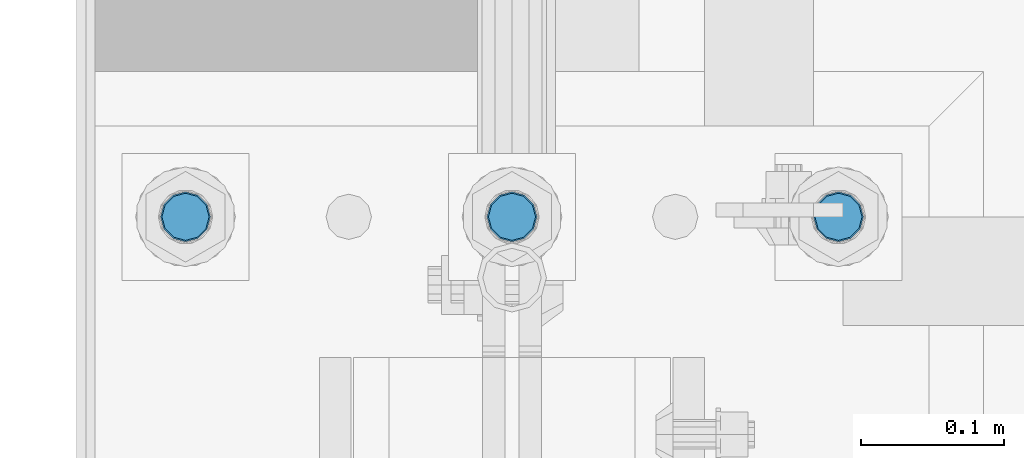
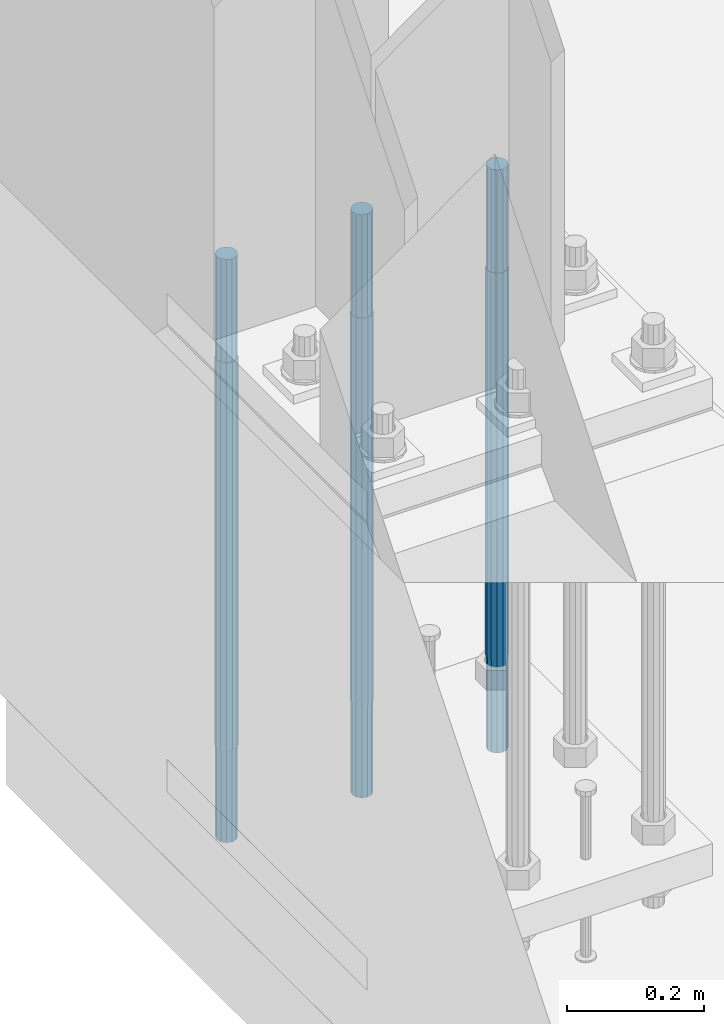
# One storey, part 565 of 1876: 3 columns, 1 element without a shape of its own.
"""IFC2X3 building model written with IfcOpenShell, lengths in millimetres."""

import ifcopenshell
import ifcopenshell.guid

model = None  # the IFC model being written
_history = None  # IfcOwnerHistory: only IFC2X3 demands one
_inside = {}  # id of a spatial element -> (the spatial element, [elements in it])
_under = {}  # id of a project, library or spatial element -> (it, [spatial elements below it])
_declared = {}  # id of a project -> (the project, [libraries it declares])
_typed = {}  # id of a type object -> (the type object, [elements of that type])
_made_of = {}  # id of a material, layer set ... -> (it, [elements and type objects made of it])


def new_model(schema):
    """Start an empty IFC model of exactly this schema.

    Asked for "IFC4X3", IfcOpenShell would pick the latest addendum, in which some entities
    have other attributes; the version numbers below select the first issue.
    IFC2X3 requires an IfcOwnerHistory on every rooted entity: one is made here for all.
    """
    global model, _history
    if schema == "IFC4X3":
        model = ifcopenshell.file(schema_version=(4, 3, 0, 0))
    else:
        model = ifcopenshell.file(schema=schema)
    _inside.clear()
    _under.clear()
    _declared.clear()
    _typed.clear()
    _made_of.clear()
    _history = None
    if model.schema == "IFC2X3":
        org = make("IfcOrganization", Name="unknown")
        user = make(
            "IfcPersonAndOrganization",
            ThePerson=make("IfcPerson", FamilyName="unknown"),
            TheOrganization=org,
        )
        app = make(
            "IfcApplication",
            ApplicationDeveloper=org,
            Version="unknown",
            ApplicationFullName="unknown",
            ApplicationIdentifier="unknown",
        )
        _history = make(
            "IfcOwnerHistory",
            OwningUser=user,
            OwningApplication=app,
            ChangeAction="ADDED",
            CreationDate=0,
        )
    return model


def make(cls, **values):
    """One entity of the class cls with the attributes given. An attribute that is None is left unset."""
    return model.create_entity(
        cls, **{name: value for name, value in values.items() if value is not None}
    )


def rooted(cls, **values):
    """An entity with a GlobalId (a new one), such as an element, a storey or a relation."""
    return make(cls, GlobalId=ifcopenshell.guid.new(), OwnerHistory=_history, **values)


def si_unit(unit_type, name, prefix=None):
    """IfcSIUnit, for example si_unit("LENGTHUNIT", "METRE", prefix="MILLI")."""
    return make("IfcSIUnit", UnitType=unit_type, Prefix=prefix, Name=name)


def assignment(units):
    """IfcUnitAssignment: the units of a project."""
    return None if units is None else make("IfcUnitAssignment", Units=units)


def point(xyz):
    """IfcCartesianPoint."""
    return None if xyz is None else make("IfcCartesianPoint", Coordinates=xyz)


def direction(xyz):
    """IfcDirection."""
    return None if xyz is None else make("IfcDirection", DirectionRatios=xyz)


def frame(location, z_axis=None, x_axis=None):
    """IfcAxis2Placement3D, a coordinate frame: its origin and axes. An axis left out is left unset."""
    return make(
        "IfcAxis2Placement3D",
        Location=point(location),
        Axis=direction(z_axis),
        RefDirection=direction(x_axis),
    )


def origin_with_axes():
    """The frame at (0, 0, 0) with the z axis (0, 0, 1) and the x axis (1, 0, 0) written out."""
    return frame((0.0, 0.0, 0.0), z_axis=(0.0, 0.0, 1.0), x_axis=(1.0, 0.0, 0.0))


def place(relative_to, where):
    """IfcLocalPlacement: puts the frame where relative to a parent placement (None: the world)."""
    return make(
        "IfcLocalPlacement", PlacementRelTo=relative_to, RelativePlacement=where
    )


def context(
    kind, dimensions, precision=None, world=None, true_north=None, identifier=None
):
    """IfcGeometricRepresentationContext, for example the 3D "Model" context."""
    return make(
        "IfcGeometricRepresentationContext",
        ContextIdentifier=identifier,
        ContextType=kind,
        CoordinateSpaceDimension=dimensions,
        Precision=precision,
        WorldCoordinateSystem=world,
        TrueNorth=true_north,
    )


def subcontext(parent, identifier, kind, view, scale=None):
    """IfcGeometricRepresentationSubContext, for example "Body" below "Model"."""
    return make(
        "IfcGeometricRepresentationSubContext",
        ContextIdentifier=identifier,
        ContextType=kind,
        ParentContext=parent,
        TargetScale=scale,
        TargetView=view,
    )


def project(units=None, contexts=None):
    """IfcProject with its units and contexts."""
    return rooted(
        "IfcProject",
        Name="project",
        RepresentationContexts=contexts,
        UnitsInContext=assignment(units),
    )


def spatial(cls, under=None, at=None, **own):
    """A site, building, storey or space (cls), placed at a placement, below another one or the project."""
    s = rooted(cls, ObjectPlacement=at, **own)
    if under is not None:
        _under.setdefault(under.id(), (under, []))[1].append(s)
    return s


def faces_of(points, faces, orient=None, outer=None):
    """IfcFace entities. A face is a list of loops; a loop is a list of indices into points, from 0.

    orient and outer hold one flag for each loop. By default every Orientation is true, the
    first loop of a face is its IfcFaceOuterBound and the others are IfcFaceBound.
    """
    made = []
    for i, loops in enumerate(faces):
        bounds = []
        for j, loop in enumerate(loops):
            is_outer = j == 0 if outer is None else outer[i][j]
            bounds.append(
                make(
                    "IfcFaceOuterBound" if is_outer else "IfcFaceBound",
                    Bound=make("IfcPolyLoop", Polygon=[points[k] for k in loop]),
                    Orientation=True if orient is None else orient[i][j],
                )
            )
        made.append(make("IfcFace", Bounds=bounds))
    return made


def faceted_brep(points, faces, orient=None, outer=None, voids=None):
    """IfcFacetedBrep: a solid bounded by flat faces; with voids (closed shells), ...WithVoids."""
    shared = [point(p) for p in points]
    hull = make("IfcClosedShell", CfsFaces=faces_of(shared, faces, orient, outer))
    if voids is None:
        return make("IfcFacetedBrep", Outer=hull)
    return make(
        "IfcFacetedBrepWithVoids",
        Outer=hull,
        Voids=[
            make(cls, CfsFaces=faces_of(shared, fs, o, b)) for cls, fs, o, b in voids
        ],
    )


def shape(context_of_items, identifier, shape_type, items):
    """IfcShapeRepresentation: the items that make up one representation, for example the "Body"."""
    return make(
        "IfcShapeRepresentation",
        ContextOfItems=context_of_items,
        RepresentationIdentifier=identifier,
        RepresentationType=shape_type,
        Items=items,
    )


def material(Name=None, Category=None):
    """IfcMaterial."""
    return make("IfcMaterial", Name=Name, Category=Category)


def made_of(thing, what):
    """Note that an element or type object is made of a material, layer set ...; save() writes the relation."""
    if what is not None:
        _made_of.setdefault(what.id(), (what, []))[1].append(thing)
    return thing


def type_object(cls, material=None, **own):
    """A type object (cls), such as IfcWallType, which elements share."""
    return made_of(rooted(cls, **own), material)


def element(
    cls,
    number,
    at=None,
    inside=None,
    cuts=None,
    type_object=None,
    material=None,
    context=None,
    identifier="Body",
    shape_type=None,
    held_by="IfcProductDefinitionShape",
    body=None,
    shapes=None,
    **own,
):
    """One element of the class cls, such as IfcWall. Its Tag is "e" and its number.

    at: its placement. inside: the storey or other place that contains it. cuts: it is an
    opening in that element (IfcRelVoidsElement). A single representation is given by context,
    identifier, shape_type and body (its items); several are given by shapes. held_by: the class
    of the entity that holds the representations. save() writes the other relations.
    """
    e = rooted(cls, Tag="e%d" % number, ObjectPlacement=at, **own)
    if body is not None:
        shapes = [shape(context, identifier, shape_type, body)]
    if shapes is not None:
        e.Representation = make(held_by, Representations=shapes)
    if inside is not None:
        _inside.setdefault(inside.id(), (inside, []))[1].append(e)
    if cuts is not None:
        rooted(
            "IfcRelVoidsElement", RelatingBuildingElement=cuts, RelatedOpeningElement=e
        )
    if type_object is not None:
        _typed.setdefault(type_object.id(), (type_object, []))[1].append(e)
    return made_of(e, material)


def aggregate(whole, parts):
    """IfcRelAggregates: a whole, such as a stair, and the parts it consists of."""
    return rooted("IfcRelAggregates", RelatingObject=whole, RelatedObjects=parts)


def save(model, path):
    """Write the relations noted so far, then the file.

    IfcRelAggregates (storeys below a building ...), IfcRelContainedInSpatialStructure (elements
    in a storey), IfcRelDefinesByType, IfcRelAssociatesMaterial and IfcRelDeclares: one each for
    every whole, place, type object, material and project.
    """
    for whole, parts in _under.values():
        aggregate(whole, parts)
    for where, things in _inside.values():
        rooted(
            "IfcRelContainedInSpatialStructure",
            RelatedElements=things,
            RelatingStructure=where,
        )
    for kind, things in _typed.values():
        rooted("IfcRelDefinesByType", RelatedObjects=things, RelatingType=kind)
    for what, things in _made_of.values():
        rooted("IfcRelAssociatesMaterial", RelatedObjects=things, RelatingMaterial=what)
    for by, libraries in _declared.values():
        rooted("IfcRelDeclares", RelatingContext=by, RelatedDefinitions=libraries)
    model.write(path)


model = new_model("IFC2X3")

# Units and contexts
model_context = context("Model", 3, precision=1e-05, world=origin_with_axes())
body_context = subcontext(model_context, "Body", "Model", "MODEL_VIEW")
ifc_project = project(units=[si_unit("LENGTHUNIT", "METRE", prefix="MILLI"), si_unit("AREAUNIT", "SQUARE_METRE"), si_unit("VOLUMEUNIT", "CUBIC_METRE"), si_unit("MASSUNIT", "GRAM", prefix="KILO"), si_unit("TIMEUNIT", "SECOND"), si_unit("PLANEANGLEUNIT", "RADIAN"), si_unit("SOLIDANGLEUNIT", "STERADIAN"), si_unit("THERMODYNAMICTEMPERATUREUNIT", "DEGREE_CELSIUS"), si_unit("LUMINOUSINTENSITYUNIT", "LUMEN")], contexts=[model_context])

# Site, building, storey
site_placement = place(None, origin_with_axes())
site = spatial("IfcSite", under=ifc_project, at=site_placement, CompositionType="ELEMENT")
building_placement = place(site_placement, origin_with_axes())
building = spatial("IfcBuilding", under=site, at=building_placement, Name="Undefined", CompositionType="ELEMENT")
storey_placement = place(building_placement, origin_with_axes())
storey = spatial("IfcBuildingStorey", under=building, at=storey_placement, Name="Undefined", CompositionType="ELEMENT", Elevation=0.0)

# Assembly, columns
assembly_placement = place(storey_placement, origin_with_axes())
assembly = element("IfcElementAssembly", 1, at=assembly_placement, inside=storey, Name="TEMPLATE", AssemblyPlace="NOTDEFINED", PredefinedType="RIGID_FRAME")
ifc_material = material(Name="STEEL/F1554-GR.105")
column_type = type_object("IfcColumnType", PredefinedType="NOTDEFINED")
column_1_placement = place(assembly_placement, frame((228.6, -6883.4, 0.0), z_axis=(-1.0, 0.0, 0.0), x_axis=(0.0, 0.0, -1.0)))
column_1 = element("IfcColumn", 2, at=column_1_placement, type_object=column_type, material=ifc_material, Name="ANCHOR_BOLTS", context=body_context, shape_type="Brep", body=[
    faceted_brep([(-184.15, -14.2894191624437, 8.25), (-184.15, -8.25, 14.2894191624432), (-184.15, 0.0, 16.5), (-184.15, 8.25, 14.2894191624432), (-184.15, 14.2894191624437, 8.25), (-184.15, 16.5, 0.0), (-184.15, 14.2894191624437, -8.25), (-184.15, 8.25, -14.2894191624432), (-184.15, 0.0, -16.5), (-184.15, -8.25, -14.2894191624432), (-184.15, -14.2894191624437, -8.25), (-184.15, -16.5, 0.0), (0.0, 16.5, 0.0), (0.0, 14.2894191624437, -8.25), (0.0, 8.25, -14.2894191624432), (0.0, 0.0, -16.5), (0.0, -8.25, -14.2894191624432), (0.0, -14.2894191624437, -8.25), (0.0, -16.5, 0.0), (0.0, -14.2894191624437, 8.25), (0.0, -8.25, 14.2894191624432), (0.0, 0.0, 16.5), (0.0, 8.25, 14.2894191624432), (0.0, 14.2894191624437, 8.25), (0.0, -15.1229686135858, 8.73125000000073), (0.0, -8.73124999999999, 15.1229686135848), (0.0, 0.0, 17.4625000000015), (0.0, 8.73124999999999, 15.1229686135848), (0.0, 15.1229686135858, 8.73125000000073), (0.0, 17.4625, 0.0), (0.0, 15.1229686135858, -8.73125000000073), (0.0, 8.73124999999999, -15.1229686135848), (0.0, 0.0, -17.4625000000015), (0.0, -8.73124999999999, -15.1229686135848), (0.0, -15.1229686135857, -8.73125000000073), (0.0, -17.4625, 0.0), (692.15, -17.4624999999996, 0.0), (692.15, -15.1229686135857, 8.73124999999982), (692.15, -8.73124999999982, 15.1229686135857), (692.15, 0.0, 17.4624999999996), (692.15, 8.73124999999982, 15.1229686135857), (692.15, 15.1229686135857, 8.73124999999982), (692.15, 17.4624999999996, 0.0), (692.15, 15.1229686135857, -8.73124999999982), (692.15, 8.73124999999982, -15.1229686135857), (692.15, 0.0, -17.4624999999996), (692.15, -8.73124999999982, -15.1229686135857), (692.15, -15.1229686135857, -8.73124999999982), (692.15, -8.25, 14.2894191624437), (692.15, 0.0, 16.5), (692.15, 8.25, 14.2894191624437), (692.15, 14.2894191624437, 8.25), (692.15, 16.5, 0.0), (692.15, 14.2894191624437, -8.25), (692.15, 8.25, -14.2894191624437), (692.15, 0.0, -16.5), (692.15, -8.25, -14.2894191624437), (692.15, -14.2894191624437, -8.25), (692.15, -16.5, 0.0), (692.15, -14.2894191624437, 8.25), (857.25, -8.25, -14.2894191624437), (857.25, 0.0, -16.5), (857.25, 8.25, -14.2894191624437), (857.25, 14.2894191624437, -8.25), (857.25, 16.5, 0.0), (857.25, 14.2894191624437, 8.25), (857.25, 8.25, 14.2894191624437), (857.25, 0.0, 16.5), (857.25, -8.25, 14.2894191624437), (857.25, -14.2894191624437, 8.25), (857.25, -16.5, 0.0), (857.25, -14.2894191624437, -8.25)], [[[0, 1, 2, 3, 4, 5, 6, 7, 8, 9, 10, 11]], [[6, 5, 12, 13]], [[7, 6, 13, 14]], [[8, 7, 14, 15]], [[9, 8, 15, 16]], [[10, 9, 16, 17]], [[11, 10, 17, 18]], [[0, 11, 18, 19]], [[1, 0, 19, 20]], [[2, 1, 20, 21]], [[3, 2, 21, 22]], [[4, 3, 22, 23]], [[5, 4, 23, 12]], [[24, 25, 26, 27, 28, 29, 30, 31, 32, 33, 34, 35], [22, 21, 20, 19, 18, 17, 16, 15, 14, 13, 12, 23]], [[24, 35, 36, 37]], [[25, 24, 37, 38]], [[26, 25, 38, 39]], [[27, 26, 39, 40]], [[28, 27, 40, 41]], [[29, 28, 41, 42]], [[30, 29, 42, 43]], [[31, 30, 43, 44]], [[32, 31, 44, 45]], [[33, 32, 45, 46]], [[34, 33, 46, 47]], [[35, 34, 47, 36]], [[46, 45, 44, 43, 42, 41, 40, 39, 38, 37, 36, 47], [48, 49, 50, 51, 52, 53, 54, 55, 56, 57, 58, 59]], [[60, 61, 62, 63, 64, 65, 66, 67, 68, 69, 70, 71]], [[68, 67, 49, 48]], [[69, 68, 48, 59]], [[70, 69, 59, 58]], [[71, 70, 58, 57]], [[60, 71, 57, 56]], [[61, 60, 56, 55]], [[62, 61, 55, 54]], [[63, 62, 54, 53]], [[64, 63, 53, 52]], [[65, 64, 52, 51]], [[66, 65, 51, 50]], [[67, 66, 50, 49]]]),
])
column_2_placement = place(assembly_placement, frame((-1.13686837721616e-13, -6883.4, 0.0), z_axis=(-1.0, 0.0, 0.0), x_axis=(0.0, 0.0, -1.0)))
column_2 = element("IfcColumn", 3, at=column_2_placement, type_object=column_type, material=ifc_material, Name="ANCHOR_BOLTS", context=body_context, shape_type="Brep", body=[
    faceted_brep([(-184.15, -14.2894191624437, 8.25), (-184.15, -8.25, 14.2894191624432), (-184.15, 0.0, 16.5), (-184.15, 8.25, 14.2894191624432), (-184.15, 14.2894191624437, 8.25), (-184.15, 16.5, 0.0), (-184.15, 14.2894191624437, -8.25), (-184.15, 8.25, -14.2894191624432), (-184.15, 0.0, -16.5), (-184.15, -8.25, -14.2894191624432), (-184.15, -14.2894191624437, -8.25), (-184.15, -16.5, 0.0), (0.0, 16.5, 0.0), (0.0, 14.2894191624437, -8.25), (0.0, 8.25, -14.2894191624432), (0.0, 0.0, -16.5), (0.0, -8.25, -14.2894191624432), (0.0, -14.2894191624437, -8.25), (0.0, -16.5, 0.0), (0.0, -14.2894191624437, 8.25), (0.0, -8.25, 14.2894191624432), (0.0, 0.0, 16.5), (0.0, 8.25, 14.2894191624432), (0.0, 14.2894191624437, 8.25), (0.0, -15.1229686135858, 8.73125000000073), (0.0, -8.73124999999999, 15.1229686135848), (0.0, 0.0, 17.4625000000015), (0.0, 8.73124999999999, 15.1229686135848), (0.0, 15.1229686135858, 8.73125000000073), (0.0, 17.4625, 0.0), (0.0, 15.1229686135858, -8.73125000000073), (0.0, 8.73124999999999, -15.1229686135848), (0.0, 0.0, -17.4625000000015), (0.0, -8.73124999999999, -15.1229686135848), (0.0, -15.1229686135857, -8.73125000000073), (0.0, -17.4625, 0.0), (692.15, -17.4624999999996, 0.0), (692.15, -15.1229686135857, 8.73124999999982), (692.15, -8.73124999999982, 15.1229686135857), (692.15, 0.0, 17.4624999999996), (692.15, 8.73124999999982, 15.1229686135857), (692.15, 15.1229686135857, 8.73124999999982), (692.15, 17.4624999999996, 0.0), (692.15, 15.1229686135857, -8.73124999999982), (692.15, 8.73124999999982, -15.1229686135857), (692.15, 0.0, -17.4624999999996), (692.15, -8.73124999999982, -15.1229686135857), (692.15, -15.1229686135857, -8.73124999999982), (692.15, -8.25, 14.2894191624437), (692.15, 0.0, 16.5), (692.15, 8.25, 14.2894191624437), (692.15, 14.2894191624437, 8.25), (692.15, 16.5, 0.0), (692.15, 14.2894191624437, -8.25), (692.15, 8.25, -14.2894191624437), (692.15, 0.0, -16.5), (692.15, -8.25, -14.2894191624437), (692.15, -14.2894191624437, -8.25), (692.15, -16.5, 0.0), (692.15, -14.2894191624437, 8.25), (857.25, -8.25, -14.2894191624437), (857.25, 0.0, -16.5), (857.25, 8.25, -14.2894191624437), (857.25, 14.2894191624437, -8.25), (857.25, 16.5, 0.0), (857.25, 14.2894191624437, 8.25), (857.25, 8.25, 14.2894191624437), (857.25, 0.0, 16.5), (857.25, -8.25, 14.2894191624437), (857.25, -14.2894191624437, 8.25), (857.25, -16.5, 0.0), (857.25, -14.2894191624437, -8.25)], [[[0, 1, 2, 3, 4, 5, 6, 7, 8, 9, 10, 11]], [[6, 5, 12, 13]], [[7, 6, 13, 14]], [[8, 7, 14, 15]], [[9, 8, 15, 16]], [[10, 9, 16, 17]], [[11, 10, 17, 18]], [[0, 11, 18, 19]], [[1, 0, 19, 20]], [[2, 1, 20, 21]], [[3, 2, 21, 22]], [[4, 3, 22, 23]], [[5, 4, 23, 12]], [[24, 25, 26, 27, 28, 29, 30, 31, 32, 33, 34, 35], [22, 21, 20, 19, 18, 17, 16, 15, 14, 13, 12, 23]], [[24, 35, 36, 37]], [[25, 24, 37, 38]], [[26, 25, 38, 39]], [[27, 26, 39, 40]], [[28, 27, 40, 41]], [[29, 28, 41, 42]], [[30, 29, 42, 43]], [[31, 30, 43, 44]], [[32, 31, 44, 45]], [[33, 32, 45, 46]], [[34, 33, 46, 47]], [[35, 34, 47, 36]], [[46, 45, 44, 43, 42, 41, 40, 39, 38, 37, 36, 47], [48, 49, 50, 51, 52, 53, 54, 55, 56, 57, 58, 59]], [[60, 61, 62, 63, 64, 65, 66, 67, 68, 69, 70, 71]], [[68, 67, 49, 48]], [[69, 68, 48, 59]], [[70, 69, 59, 58]], [[71, 70, 58, 57]], [[60, 71, 57, 56]], [[61, 60, 56, 55]], [[62, 61, 55, 54]], [[63, 62, 54, 53]], [[64, 63, 53, 52]], [[65, 64, 52, 51]], [[66, 65, 51, 50]], [[67, 66, 50, 49]]]),
])
column_3_placement = place(assembly_placement, frame((-228.6, -6883.4, 0.0), z_axis=(-1.0, 0.0, 0.0), x_axis=(0.0, 0.0, -1.0)))
column_3 = element("IfcColumn", 4, at=column_3_placement, type_object=column_type, material=ifc_material, Name="ANCHOR_BOLTS", context=body_context, shape_type="Brep", body=[
    faceted_brep([(-184.15, -14.2894191624437, 8.25), (-184.15, -8.25, 14.2894191624432), (-184.15, 0.0, 16.5), (-184.15, 8.25, 14.2894191624432), (-184.15, 14.2894191624437, 8.25), (-184.15, 16.5, 0.0), (-184.15, 14.2894191624437, -8.25), (-184.15, 8.25, -14.2894191624432), (-184.15, 0.0, -16.5), (-184.15, -8.25, -14.2894191624432), (-184.15, -14.2894191624437, -8.25), (-184.15, -16.5, 0.0), (0.0, 16.5, 0.0), (0.0, 14.2894191624437, -8.25), (0.0, 8.25, -14.2894191624432), (0.0, 0.0, -16.5), (0.0, -8.25, -14.2894191624432), (0.0, -14.2894191624437, -8.25), (0.0, -16.5, 0.0), (0.0, -14.2894191624437, 8.25), (0.0, -8.25, 14.2894191624432), (0.0, 0.0, 16.5), (0.0, 8.25, 14.2894191624432), (0.0, 14.2894191624437, 8.25), (0.0, -15.1229686135858, 8.73125000000073), (0.0, -8.73124999999999, 15.1229686135848), (0.0, 0.0, 17.4625000000015), (0.0, 8.73124999999999, 15.1229686135848), (0.0, 15.1229686135858, 8.73125000000073), (0.0, 17.4625, 0.0), (0.0, 15.1229686135858, -8.73125000000073), (0.0, 8.73124999999999, -15.1229686135848), (0.0, 0.0, -17.4625000000015), (0.0, -8.73124999999999, -15.1229686135848), (0.0, -15.1229686135857, -8.73125000000073), (0.0, -17.4625, 0.0), (692.15, -17.4624999999996, 0.0), (692.15, -15.1229686135857, 8.73124999999982), (692.15, -8.73124999999982, 15.1229686135857), (692.15, 0.0, 17.4624999999996), (692.15, 8.73124999999982, 15.1229686135857), (692.15, 15.1229686135857, 8.73124999999982), (692.15, 17.4624999999996, 0.0), (692.15, 15.1229686135857, -8.73124999999982), (692.15, 8.73124999999982, -15.1229686135857), (692.15, 0.0, -17.4624999999996), (692.15, -8.73124999999982, -15.1229686135857), (692.15, -15.1229686135857, -8.73124999999982), (692.15, -8.25, 14.2894191624437), (692.15, 0.0, 16.5), (692.15, 8.25, 14.2894191624437), (692.15, 14.2894191624437, 8.25), (692.15, 16.5, 0.0), (692.15, 14.2894191624437, -8.25), (692.15, 8.25, -14.2894191624437), (692.15, 0.0, -16.5), (692.15, -8.25, -14.2894191624437), (692.15, -14.2894191624437, -8.25), (692.15, -16.5, 0.0), (692.15, -14.2894191624437, 8.25), (857.25, -8.25, -14.2894191624437), (857.25, 0.0, -16.5), (857.25, 8.25, -14.2894191624437), (857.25, 14.2894191624437, -8.25), (857.25, 16.5, 0.0), (857.25, 14.2894191624437, 8.25), (857.25, 8.25, 14.2894191624437), (857.25, 0.0, 16.5), (857.25, -8.25, 14.2894191624437), (857.25, -14.2894191624437, 8.25), (857.25, -16.5, 0.0), (857.25, -14.2894191624437, -8.25)], [[[0, 1, 2, 3, 4, 5, 6, 7, 8, 9, 10, 11]], [[6, 5, 12, 13]], [[7, 6, 13, 14]], [[8, 7, 14, 15]], [[9, 8, 15, 16]], [[10, 9, 16, 17]], [[11, 10, 17, 18]], [[0, 11, 18, 19]], [[1, 0, 19, 20]], [[2, 1, 20, 21]], [[3, 2, 21, 22]], [[4, 3, 22, 23]], [[5, 4, 23, 12]], [[24, 25, 26, 27, 28, 29, 30, 31, 32, 33, 34, 35], [22, 21, 20, 19, 18, 17, 16, 15, 14, 13, 12, 23]], [[24, 35, 36, 37]], [[25, 24, 37, 38]], [[26, 25, 38, 39]], [[27, 26, 39, 40]], [[28, 27, 40, 41]], [[29, 28, 41, 42]], [[30, 29, 42, 43]], [[31, 30, 43, 44]], [[32, 31, 44, 45]], [[33, 32, 45, 46]], [[34, 33, 46, 47]], [[35, 34, 47, 36]], [[46, 45, 44, 43, 42, 41, 40, 39, 38, 37, 36, 47], [48, 49, 50, 51, 52, 53, 54, 55, 56, 57, 58, 59]], [[60, 61, 62, 63, 64, 65, 66, 67, 68, 69, 70, 71]], [[68, 67, 49, 48]], [[69, 68, 48, 59]], [[70, 69, 59, 58]], [[71, 70, 58, 57]], [[60, 71, 57, 56]], [[61, 60, 56, 55]], [[62, 61, 55, 54]], [[63, 62, 54, 53]], [[64, 63, 53, 52]], [[65, 64, 52, 51]], [[66, 65, 51, 50]], [[67, 66, 50, 49]]]),
])
aggregate(assembly, [column_1, column_2, column_3])

save(model, "model.ifc")
